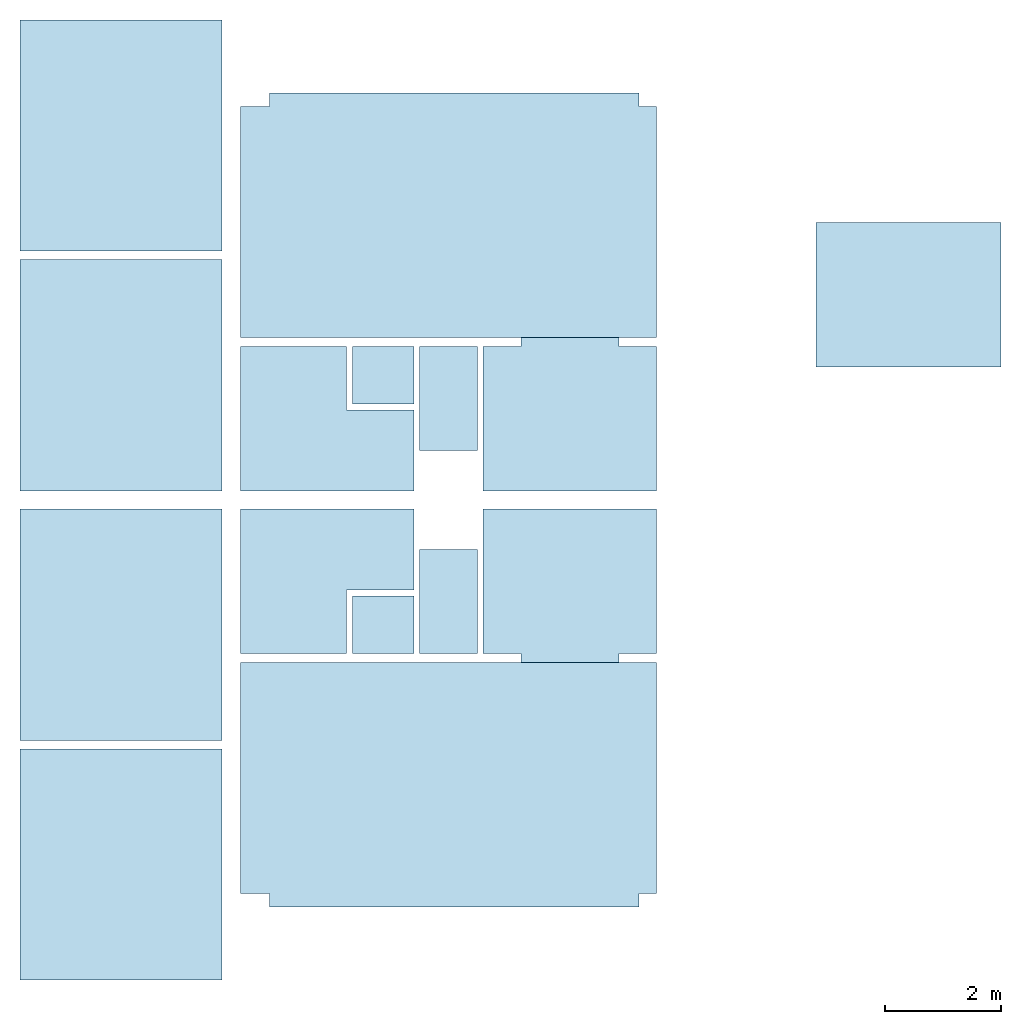
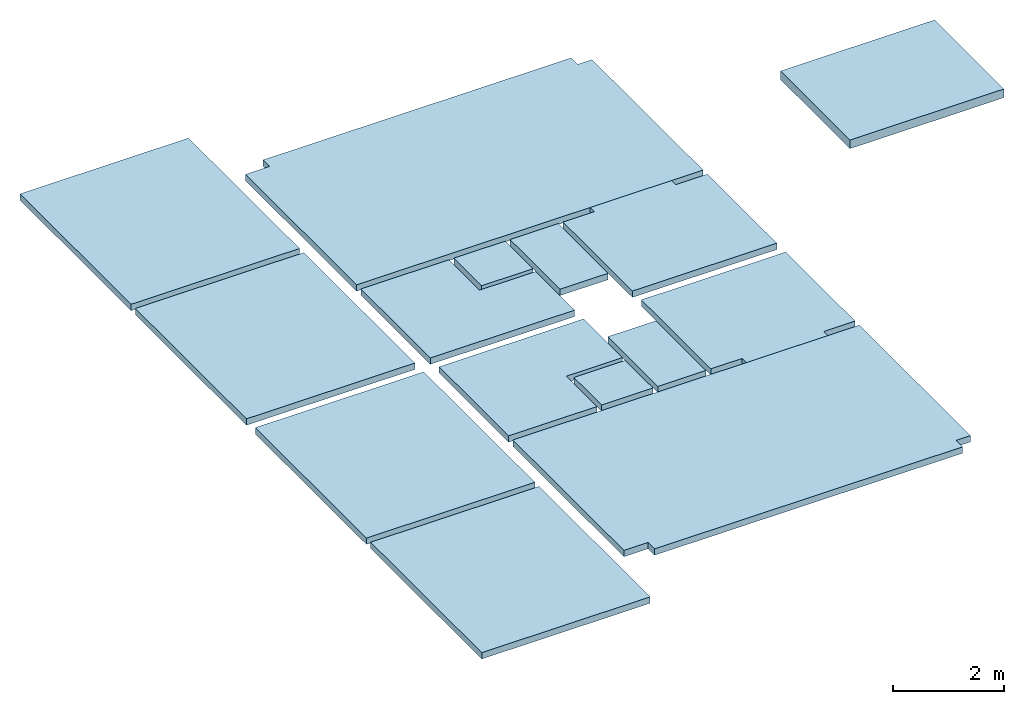
# One storey: 15 slabs.
"""IFC2X3 building model written with IfcOpenShell, lengths in millimetres."""

from ifc_helpers import new_model, entity, si_unit, converted_unit, derived_unit, direction, frame, frame_2d, origin, origin_2d_with_axis, place, context, subcontext, project, spatial, polyline, rectangle, outline, extrude, material, layer, layer_set, layer_usage, type_object, element, save


model = new_model("IFC2X3")

# Units and contexts
model_context = context("Model", 3, precision=0.01, world=origin(), true_north=direction((6.12303176911189e-17, 1.0)))
body_context = subcontext(model_context, "Body", "Model", "MODEL_VIEW")
ifc_project = project(units=[si_unit("LENGTHUNIT", "METRE", prefix="MILLI"), si_unit("AREAUNIT", "SQUARE_METRE"), si_unit("VOLUMEUNIT", "CUBIC_METRE"), converted_unit("PLANEANGLEUNIT", "DEGREE", entity("IfcRatioMeasure", 0.0174532925199433), si_unit("PLANEANGLEUNIT", "RADIAN"), dimensions=[0, 0, 0, 0, 0, 0, 0]), si_unit("MASSUNIT", "GRAM", prefix="KILO"), derived_unit("MASSDENSITYUNIT", [(si_unit("MASSUNIT", "GRAM", prefix="KILO"), 1), (si_unit("LENGTHUNIT", "METRE"), -3)]), si_unit("TIMEUNIT", "SECOND"), si_unit("FREQUENCYUNIT", "HERTZ"), si_unit("THERMODYNAMICTEMPERATUREUNIT", "DEGREE_CELSIUS"), derived_unit("THERMALTRANSMITTANCEUNIT", [(si_unit("MASSUNIT", "GRAM", prefix="KILO"), 1), (si_unit("THERMODYNAMICTEMPERATUREUNIT", "KELVIN"), -1), (si_unit("TIMEUNIT", "SECOND"), -3)]), derived_unit("VOLUMETRICFLOWRATEUNIT", [(si_unit("LENGTHUNIT", "METRE"), 3), (si_unit("TIMEUNIT", "SECOND"), -1)]), si_unit("ELECTRICCURRENTUNIT", "AMPERE"), si_unit("ELECTRICVOLTAGEUNIT", "VOLT"), si_unit("POWERUNIT", "WATT"), si_unit("FORCEUNIT", "NEWTON", prefix="KILO"), si_unit("ILLUMINANCEUNIT", "LUX"), si_unit("LUMINOUSFLUXUNIT", "LUMEN"), si_unit("LUMINOUSINTENSITYUNIT", "CANDELA"), derived_unit("USERDEFINED", [(si_unit("MASSUNIT", "GRAM", prefix="KILO"), -1), (si_unit("LENGTHUNIT", "METRE"), -2), (si_unit("TIMEUNIT", "SECOND"), 3), (si_unit("LUMINOUSFLUXUNIT", "LUMEN"), 1)]), derived_unit("LINEARVELOCITYUNIT", [(si_unit("LENGTHUNIT", "METRE"), 1), (si_unit("TIMEUNIT", "SECOND"), -1)]), si_unit("PRESSUREUNIT", "PASCAL"), derived_unit("USERDEFINED", [(si_unit("LENGTHUNIT", "METRE"), -2), (si_unit("MASSUNIT", "GRAM", prefix="KILO"), 1), (si_unit("TIMEUNIT", "SECOND"), -2)])], contexts=[model_context])

# Site, building, storey
site_placement = place(None, origin())
site = spatial("IfcSite", under=ifc_project, at=site_placement, CompositionType="ELEMENT")
building_placement = place(site_placement, origin())
building = spatial("IfcBuilding", under=site, at=building_placement, CompositionType="ELEMENT")
storey_placement = place(building_placement, frame((0.0, 0.0, 4000.0)))
storey = spatial("IfcBuildingStorey", under=building, at=storey_placement, Name="01 Level", CompositionType="ELEMENT", Elevation=4000.0)

# Slabs
ifc_material_1 = material(Name="05_Fa")
ifc_layer_1 = layer(ifc_material_1, 10.0)
ifc_material_2 = material(Name="06")
ifc_layer_2 = layer(ifc_material_2, 5.0)
ifc_material_3 = material(Name="02_Beton, C40/55")
ifc_layer_3 = layer(ifc_material_3, 60.0)
ifc_material_4 = material()
ifc_layer_4 = layer(ifc_material_4, 65.0)
ifc_layer_set_1 = layer_set([ifc_layer_1, ifc_layer_2, ifc_layer_3, ifc_layer_4], Name="Floor")
ifc_layer_usage_1 = layer_usage(ifc_layer_set_1, "AXIS3", "POSITIVE", 0.0)
slab_type_1 = type_object("IfcSlabType", Name="Floor", PredefinedType="FLOOR", material=ifc_layer_set_1)
slab_1_placement = place(storey_placement, origin())
element("IfcSlab", 1, at=slab_1_placement, inside=storey, type_object=slab_type_1, material=ifc_layer_usage_1, Name="Floor", ObjectType="Floor", PredefinedType="FLOOR", context=body_context, shape_type="SweptSolid", body=[
    extrude(rectangle(XDim=4000.00000000001, YDim=3500.00000000001, at=frame_2d((0.0, 1.13686837721616e-12), x_axis=(1.0, 0.0))), frame((19233.4900708518, -70991.2395851399, 0.0), z_axis=(0.0, 0.0, -1.0), x_axis=(0.0, 1.0, 0.0)), (0.0, 0.0, 1.0), 140.0),
])
ifc_material_5 = material(Name="07")
ifc_layer_5 = layer(ifc_material_5, 15.0)
ifc_material_6 = material(Name="06")
ifc_layer_6 = layer(ifc_material_6, 5.0)
ifc_layer_7 = layer(ifc_material_3, 60.0)
ifc_material_7 = material(Name="04_XPS PLUS 30 SF")
ifc_layer_8 = layer(ifc_material_7, 110.0)
ifc_layer_set_2 = layer_set([ifc_layer_5, ifc_layer_6, ifc_layer_7, ifc_layer_8], Name="Floor")
ifc_layer_usage_2 = layer_usage(ifc_layer_set_2, "AXIS3", "POSITIVE", 0.0)
slab_type_2 = type_object("IfcSlabType", Name="Floor", PredefinedType="FLOOR", material=ifc_layer_set_2)
slab_2_placement = place(storey_placement, origin())
element("IfcSlab", 2, at=slab_2_placement, inside=storey, type_object=slab_type_2, material=ifc_layer_usage_2, Name="Floor", ObjectType="Floor", PredefinedType="FLOOR", context=body_context, shape_type="SweptSolid", body=[
    extrude(rectangle(XDim=2500.0, YDim=3199.99999999998, at=origin_2d_with_axis()), frame((32863.4900708518, -65275.8241905964, 0.0), z_axis=(0.0, 0.0, -1.0), x_axis=(0.0, 1.0, 0.0)), (0.0, 0.0, 1.0), 190.0),
])
ifc_layer_9 = layer(ifc_material_5, 15.0)
ifc_layer_10 = layer(ifc_material_6, 5.0)
ifc_material_8 = material(Name="02_C40/55")
ifc_layer_11 = layer(ifc_material_8, 60.0)
ifc_layer_12 = layer(ifc_material_4, 60.0)
ifc_layer_set_3 = layer_set([ifc_layer_9, ifc_layer_10, ifc_layer_11, ifc_layer_12], Name="Floor")
ifc_layer_usage_3 = layer_usage(ifc_layer_set_3, "AXIS3", "POSITIVE", 0.0)
slab_type_3 = type_object("IfcSlabType", Name="Floor", PredefinedType="FLOOR", material=ifc_layer_set_3)
slab_3_placement = place(storey_placement, origin())
element("IfcSlab", 3, at=slab_3_placement, inside=storey, type_object=slab_type_3, material=ifc_layer_usage_3, Name="Floor", ObjectType="Floor", PredefinedType="FLOOR", context=body_context, shape_type="SweptSolid", body=[
    extrude(outline(polyline([(-587.499999999996, -1500.0), (1912.50000000001, -1500.0), (1912.50000000001, 1500.0), (-587.499999999996, 1500.0), (-587.499999999996, 850.0), (-737.499999999997, 850.0), (-737.499999999988, -850.0), (-587.499999999996, -850.0), (-587.499999999996, -1500.0)])), frame((27003.4900708518, -70903.7395851399, 0.0), z_axis=(0.0, 0.0, -1.0), x_axis=(0.0, 1.0, 0.0)), (0.0, 0.0, 1.0), 140.0),
])
ifc_layer_usage_4 = layer_usage(ifc_layer_set_3, "AXIS3", "POSITIVE", 0.0)
slab_type_4 = type_object("IfcSlabType", Name="Floor", PredefinedType="FLOOR", material=ifc_layer_set_3)
slab_4_placement = place(storey_placement, origin())
element("IfcSlab", 4, at=slab_4_placement, inside=storey, type_object=slab_type_4, material=ifc_layer_usage_4, Name="Floor", ObjectType="Floor", PredefinedType="FLOOR", context=body_context, shape_type="SweptSolid", body=[
    extrude(rectangle(XDim=1800.0, YDim=1000.00000000001, at=frame_2d((-4.32009983342141e-12, 0.0), x_axis=(1.0, 0.0))), frame((24903.4900708518, -70591.2395851399, 0.0), z_axis=(0.0, 0.0, -1.0), x_axis=(0.0, 1.0, 0.0)), (0.0, 0.0, 1.0), 140.0),
])
ifc_layer_usage_5 = layer_usage(ifc_layer_set_3, "AXIS3", "POSITIVE", 0.0)
slab_type_5 = type_object("IfcSlabType", Name="Floor", PredefinedType="FLOOR", material=ifc_layer_set_3)
slab_5_placement = place(storey_placement, origin())
element("IfcSlab", 5, at=slab_5_placement, inside=storey, type_object=slab_type_5, material=ifc_layer_usage_5, Name="Floor", ObjectType="Floor", PredefinedType="FLOOR", context=body_context, shape_type="SweptSolid", body=[
    extrude(outline(polyline([(-1912.5, -1500.0), (587.500000000006, -1500.0), (587.500000000009, -850.0), (737.500000000001, -850.0), (737.50000000001, 850.0), (587.500000000001, 850.0), (587.500000000004, 1500.0), (-1912.5, 1500.0), (-1912.5, -1500.0)])), frame((27003.4900708518, -66758.7395851399, 0.0), z_axis=(0.0, 0.0, -1.0), x_axis=(0.0, 1.0, 0.0)), (0.0, 0.0, 1.0), 140.0),
])
ifc_layer_usage_6 = layer_usage(ifc_layer_set_3, "AXIS3", "POSITIVE", 0.0)
slab_type_6 = type_object("IfcSlabType", Name="Floor", PredefinedType="FLOOR", material=ifc_layer_set_3)
slab_6_placement = place(storey_placement, origin())
element("IfcSlab", 6, at=slab_6_placement, inside=storey, type_object=slab_type_6, material=ifc_layer_usage_6, Name="Floor", ObjectType="Floor", PredefinedType="FLOOR", context=body_context, shape_type="SweptSolid", body=[
    extrude(rectangle(XDim=1799.99999999999, YDim=1000.0, at=frame_2d((4.32009983342141e-12, 0.0), x_axis=(1.0, 0.0))), frame((24903.4900708518, -67071.2395851399, 0.0), z_axis=(0.0, 0.0, -1.0), x_axis=(0.0, 1.0, 0.0)), (0.0, 0.0, 1.0), 140.0),
])
ifc_layer_usage_7 = layer_usage(ifc_layer_set_1, "AXIS3", "POSITIVE", 0.0)
slab_type_7 = type_object("IfcSlabType", Name="Floor", PredefinedType="FLOOR", material=ifc_layer_set_1)
slab_7_placement = place(storey_placement, origin())
element("IfcSlab", 7, at=slab_7_placement, inside=storey, type_object=slab_type_7, material=ifc_layer_usage_7, Name="Floor", ObjectType="Floor", PredefinedType="FLOOR", context=body_context, shape_type="SweptSolid", body=[
    extrude(rectangle(XDim=4000.00000000001, YDim=3500.00000000001, at=frame_2d((0.0, 2.1600499167107e-12), x_axis=(1.0, 0.0))), frame((19233.4900708518, -75141.2395851399, 0.0), z_axis=(0.0, 0.0, -1.0), x_axis=(0.0, 1.0, 0.0)), (0.0, 0.0, 1.0), 140.0),
])
ifc_layer_usage_8 = layer_usage(ifc_layer_set_1, "AXIS3", "POSITIVE", 0.0)
slab_type_8 = type_object("IfcSlabType", Name="Floor", PredefinedType="FLOOR", material=ifc_layer_set_1)
slab_8_placement = place(storey_placement, origin())
element("IfcSlab", 8, at=slab_8_placement, inside=storey, type_object=slab_type_8, material=ifc_layer_usage_8, Name="Floor", ObjectType="Floor", PredefinedType="FLOOR", context=body_context, shape_type="SweptSolid", body=[
    extrude(rectangle(XDim=4000.00000000001, YDim=3500.00000000001, at=frame_2d((0.0, 2.1600499167107e-12), x_axis=(1.0, 0.0))), frame((19233.4900708518, -66671.2395851399, 0.0), z_axis=(0.0, 0.0, -1.0), x_axis=(0.0, 1.0, 0.0)), (0.0, 0.0, 1.0), 140.0),
])
ifc_layer_usage_9 = layer_usage(ifc_layer_set_1, "AXIS3", "POSITIVE", 0.0)
slab_type_9 = type_object("IfcSlabType", Name="Floor", PredefinedType="FLOOR", material=ifc_layer_set_1)
slab_9_placement = place(storey_placement, origin())
element("IfcSlab", 9, at=slab_9_placement, inside=storey, type_object=slab_type_9, material=ifc_layer_usage_9, Name="Floor", ObjectType="Floor", PredefinedType="FLOOR", context=body_context, shape_type="SweptSolid", body=[
    extrude(rectangle(XDim=4000.00000000001, YDim=3500.00000000001, at=frame_2d((0.0, -2.1600499167107e-12), x_axis=(1.0, 0.0))), frame((19233.4900708518, -62521.2395851399, 0.0), z_axis=(0.0, 0.0, -1.0), x_axis=(0.0, 1.0, 0.0)), (0.0, 0.0, 1.0), 140.0),
])
ifc_layer_usage_10 = layer_usage(ifc_layer_set_3, "AXIS3", "POSITIVE", 0.0)
slab_type_10 = type_object("IfcSlabType", Name="Floor", PredefinedType="FLOOR")
slab_10_placement = place(storey_placement, frame((21303.4900708518, -68671.2395851399, -140.0)))
element("IfcSlab", 10, at=slab_10_placement, inside=storey, type_object=slab_type_10, material=ifc_layer_usage_10, Name="Floor", ObjectType="Floor", PredefinedType="FLOOR", context=body_context, shape_type="SweptSolid", body=[
    extrude(outline(polyline([(-1500.0, -1250.0), (1500.0, -1250.0), (1500.0, 1250.0), (-332.500000000015, 1250.0), (-332.500000000007, 150.0), (-1500.0, 150.0), (-1500.0, -1250.0)])), frame((1500.0, 1250.0, 140.0), z_axis=(0.0, 0.0, -1.0), x_axis=(-1.0, 0.0, 0.0)), (0.0, 0.0, 1.0), 140.0),
])
slab_type_11 = type_object("IfcSlabType", Name="Floor", PredefinedType="FLOOR", material=ifc_layer_set_3)
slab_11_placement = place(storey_placement, frame((21303.4900708518, -68671.2395851399, -140.0)))
element("IfcSlab", 11, at=slab_11_placement, inside=storey, type_object=slab_type_11, material=ifc_layer_usage_10, Name="Floor:2", ObjectType="Floor", PredefinedType="FLOOR", context=body_context, shape_type="SweptSolid", body=[
    extrude(rectangle(XDim=1067.5, YDim=999.999999999998, at=frame_2d((-966.250000000001, 750.0), x_axis=(-1.0, 0.0))), frame((1500.0, 1250.0, 140.0), z_axis=(0.0, 0.0, -1.0), x_axis=(-1.0, 0.0, 0.0)), (0.0, 0.0, 1.0), 140.0),
])
ifc_layer_usage_11 = layer_usage(ifc_layer_set_3, "AXIS3", "POSITIVE", 0.0)
slab_type_12 = type_object("IfcSlabType", Name="Floor", PredefinedType="FLOOR")
slab_12_placement = place(storey_placement, frame((21303.4900708518, -71491.2395851399, -140.0)))
element("IfcSlab", 12, at=slab_12_placement, inside=storey, type_object=slab_type_12, material=ifc_layer_usage_11, Name="Floor", ObjectType="Floor", PredefinedType="FLOOR", context=body_context, shape_type="SweptSolid", body=[
    extrude(outline(polyline([(-1500.0, 1250.0), (-1500.0, -150.0), (-332.500000000007, -150.0), (-332.500000000007, -1250.0), (1500.0, -1250.0), (1500.0, 1250.0), (-1500.0, 1250.0)])), frame((1500.0, 1250.0, 140.0), z_axis=(0.0, 0.0, -1.0), x_axis=(-1.0, 0.0, 0.0)), (0.0, 0.0, 1.0), 140.0),
])
slab_type_13 = type_object("IfcSlabType", Name="Floor", PredefinedType="FLOOR", material=ifc_layer_set_3)
slab_13_placement = place(storey_placement, frame((21303.4900708518, -71491.2395851399, -140.0)))
element("IfcSlab", 13, at=slab_13_placement, inside=storey, type_object=slab_type_13, material=ifc_layer_usage_11, Name="Floor:2", ObjectType="Floor", PredefinedType="FLOOR", context=body_context, shape_type="SweptSolid", body=[
    extrude(rectangle(XDim=999.999999999998, YDim=1067.5, at=frame_2d((-966.249999999999, -750.0), x_axis=(0.0, 1.0))), frame((1500.0, 1250.0, 140.0), z_axis=(0.0, 0.0, -1.0), x_axis=(-1.0, 0.0, 0.0)), (0.0, 0.0, 1.0), 140.0),
])
ifc_layer_usage_12 = layer_usage(ifc_layer_set_1, "AXIS3", "POSITIVE", 0.0)
slab_type_14 = type_object("IfcSlabType", Name="Floor", PredefinedType="FLOOR", material=ifc_layer_set_1)
slab_14_placement = place(storey_placement, origin())
element("IfcSlab", 14, at=slab_14_placement, inside=storey, type_object=slab_type_14, material=ifc_layer_usage_12, Name="Floor", ObjectType="Floor", PredefinedType="FLOOR", context=body_context, shape_type="SweptSolid", body=[
    extrude(outline(polyline([(-3058.74999999997, -3650.0), (941.250000000018, -3650.0), (941.250000000013, -3150.0), (1176.24999999999, -3150.0), (1176.24999999999, 3250.0), (941.249999999985, 3250.0), (941.249999999987, 3550.0), (-3058.74999999997, 3550.0), (-3058.74999999997, -3650.0)])), frame((24953.4900708518, -62962.48958514, 0.0), z_axis=(0.0, 0.0, -1.0), x_axis=(0.0, 1.0, 0.0)), (0.0, 0.0, 1.0), 140.0),
])
ifc_layer_usage_13 = layer_usage(ifc_layer_set_1, "AXIS3", "POSITIVE", 0.0)
slab_type_15 = type_object("IfcSlabType", Name="Floor", PredefinedType="FLOOR", material=ifc_layer_set_1)
slab_15_placement = place(storey_placement, origin())
element("IfcSlab", 15, at=slab_15_placement, inside=storey, type_object=slab_type_15, material=ifc_layer_usage_13, Name="Floor", ObjectType="Floor", PredefinedType="FLOOR", context=body_context, shape_type="SweptSolid", body=[
    extrude(outline(polyline([(-941.250000000016, -3650.0), (3058.74999999998, -3650.0), (3058.74999999998, 3550.0), (-941.249999999981, 3550.0), (-941.249999999981, 3250.0), (-1176.25, 3250.0), (-1176.25, -3150.0), (-941.250000000016, -3150.0), (-941.250000000016, -3650.0)])), frame((24953.4900708518, -74699.9895851399, 0.0), z_axis=(0.0, 0.0, -1.0), x_axis=(0.0, 1.0, 0.0)), (0.0, 0.0, 1.0), 140.0),
])

save(model, "model.ifc")
